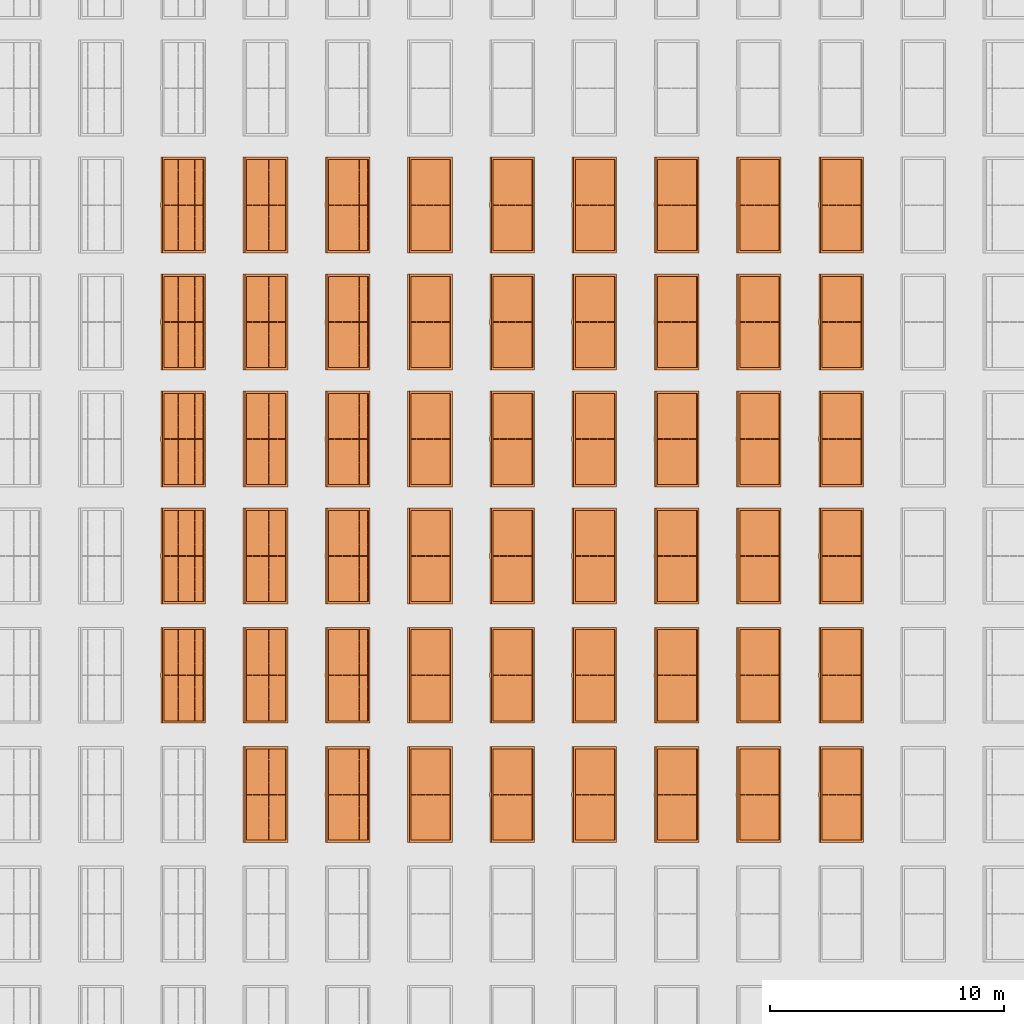
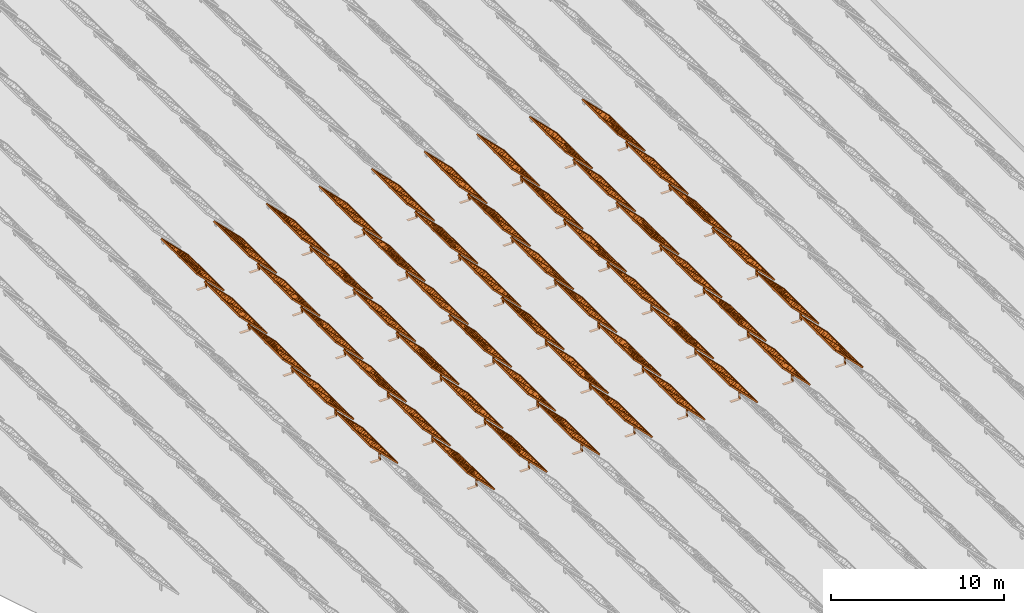
# One storey, part 17 of 39: 53 proxies.
"""IFC2X3 building model written with IfcOpenShell, lengths in millimetres."""

from ifc_helpers import new_model, entity, si_unit, converted_unit, derived_unit, direction, frame, frame_2d, origin, origin_2d_with_axis, place, context, subcontext, project, spatial, polyline, rectangle, outline, extrude, source, transform, mapped, material, material_list, element, save


model = new_model("IFC2X3")

# Units and contexts
model_context = context("Model", 3, precision=1e-06, world=origin(), true_north=direction((2.0, 6.12303176911189e-17, 1.0)))
context_of_model = context(None, 3, precision=1e-06, world=origin(), true_north=direction((2.0, 6.12303176911189e-17, 1.0)))
body_context = subcontext(model_context, "Body", "Model", "MODEL_VIEW")
ifc_project = project(units=[si_unit("LENGTHUNIT", "METRE", prefix="MILLI"), si_unit("AREAUNIT", "SQUARE_METRE", prefix="MILLI"), si_unit("VOLUMEUNIT", "CUBIC_METRE", prefix="MILLI"), converted_unit("PLANEANGLEUNIT", "DEGREE", entity("IfcRatioMeasure", 0.0174532925199433), si_unit("PLANEANGLEUNIT", "RADIAN"), dimensions=[0, 0, 0, 0, 0, 0, 0]), si_unit("MASSUNIT", "GRAM", prefix="KILO"), si_unit("TIMEUNIT", "SECOND"), si_unit("THERMODYNAMICTEMPERATUREUNIT", "KELVIN"), derived_unit("THERMALTRANSMITTANCEUNIT", [(si_unit("MASSUNIT", "GRAM", prefix="KILO"), 1), (si_unit("THERMODYNAMICTEMPERATUREUNIT", "KELVIN"), -1), (si_unit("TIMEUNIT", "SECOND"), -3)]), derived_unit("VOLUMETRICFLOWRATEUNIT", [(si_unit("LENGTHUNIT", "METRE"), 3), (si_unit("TIMEUNIT", "SECOND"), -1)])], contexts=[model_context, context_of_model])

# Site, building, storey
site_placement = place(None, origin())
site = spatial("IfcSite", under=ifc_project, at=site_placement, CompositionType="ELEMENT")
building_placement = place(site_placement, origin())
building = spatial("IfcBuilding", under=site, at=building_placement, CompositionType="ELEMENT")
storey_placement = place(building_placement, frame((0.0, 0.0, 4000.0)))
storey = spatial("IfcBuildingStorey", under=building, at=storey_placement, Name="Level 2", CompositionType="ELEMENT", Elevation=4000.0)

# Proxies
ifc_material_1 = material(Name="Stand-Steel")
ifc_material_2 = material(Name="Aluminium")
ifc_material_3 = material(Name="Glass")
ifc_material_list_1 = material_list([ifc_material_1, ifc_material_2, ifc_material_3])
shared_shape = source(origin(), body_context, "Body", "SweptSolid", [
    extrude(outline(polyline([(-629.526235435404, -220.0), (329.763117717702, -220.0), (329.763117717703, 410.0), (299.763117717703, 410.0), (299.763117717702, -190.0), (-629.526235435404, -190.0), (-629.526235435404, -220.0)])), frame((-190.00003127179, -100.0, 299.763117717707), z_axis=(0.0, 1.0, 0.0), x_axis=(0.0, 0.0, -1.0)), (0.0, 0.0, 1.0), 200.0),
    extrude(rectangle(XDim=20.0000000000001, YDim=200.0, at=frame_2d((0.0, -7.105427357601e-14), x_axis=(0.0, 1.0))), frame((-7.07109908365613, 0.0, 922.21828534124), z_axis=(-0.70710678118654, 0.0, 0.707106781186555), x_axis=(0.0, 1.0, 0.0)), (0.0, 0.0, 1.0), 2600.0),
    extrude(rectangle(XDim=24.9999999999997, YDim=24.9999999999999, at=frame_2d((2.87769807982841e-13, -9.50350909079134e-14), x_axis=(1.0, 0.0))), frame((-1449.56292018118, -1950.0, 2449.57494522722), z_axis=(0.0, 1.0, 0.0), x_axis=(-0.707106781186548, 0.0, -0.707106781186548)), (0.0, 0.0, 1.0), 3900.0),
    extrude(rectangle(XDim=24.9999999999999, YDim=25.0000000000001, at=origin_2d_with_axis()), frame((-1096.0095295879, -1950.0, 2096.02155463395), z_axis=(0.0, 1.0, 0.0), x_axis=(-0.707106781186542, 0.0, -0.707106781186553)), (0.0, 0.0, 1.0), 3900.0),
    extrude(rectangle(XDim=24.9999999999999, YDim=25.0000000000001, at=origin_2d_with_axis()), frame((-742.456138994631, -1950.0, 1742.46816404067), z_axis=(0.0, 1.0, 0.0), x_axis=(-0.707106781186542, 0.0, -0.707106781186553)), (0.0, 0.0, 1.0), 3900.0),
    extrude(rectangle(XDim=25.0, YDim=24.9999999999997, at=frame_2d((-7.19424519957101e-14, 1.19904086659517e-13), x_axis=(1.0, 0.0))), frame((-388.902748401358, -1950.0, 1388.9147734474), z_axis=(0.0, 1.0, 0.0), x_axis=(-0.707106781186545, 0.0, -0.70710678118655)), (0.0, 0.0, 1.0), 3900.0),
    extrude(rectangle(XDim=25.0000000000002, YDim=25.0, at=frame_2d((1.35891298214119e-13, 6.21724893790088e-15), x_axis=(0.0, 1.0))), frame((-35.3553703311048, 1500.0, 1035.35537033109), z_axis=(-0.707106781186544, 0.0, 0.707106781186551), x_axis=(0.0, 1.0, 0.0)), (0.0, 0.0, 1.0), 2440.0),
    extrude(rectangle(XDim=25.0000000000002, YDim=25.0, at=frame_2d((0.0, 1.77635683940025e-15), x_axis=(0.0, 1.0))), frame((-35.3553703311059, 1000.0, 1035.35537033109), z_axis=(-0.707106781186546, 0.0, 0.707106781186549), x_axis=(0.0, 1.0, 0.0)), (0.0, 0.0, 1.0), 2440.0),
    extrude(rectangle(XDim=25.0000000000002, YDim=25.0, at=frame_2d((0.0, 8.43769498715119e-14), x_axis=(0.0, 1.0))), frame((-26.5165355662756, 0.0, 1044.19420509593), z_axis=(-0.707106781186546, 0.0, 0.707106781186549), x_axis=(0.0, -1.0, 0.0)), (0.0, 0.0, 1.0), 2440.0),
    extrude(rectangle(XDim=25.0000000000002, YDim=25.0, at=frame_2d((0.0, 8.88178419700125e-16), x_axis=(0.0, 1.0))), frame((-35.3553703311065, 500.0, 1035.35537033109), z_axis=(-0.707106781186546, 0.0, 0.707106781186549), x_axis=(0.0, 1.0, 0.0)), (0.0, 0.0, 1.0), 2440.0),
    extrude(rectangle(XDim=25.0000000000002, YDim=25.0, at=frame_2d((0.0, 8.88178419700125e-16), x_axis=(0.0, 1.0))), frame((-35.3553703311086, -500.0, 1035.35537033109), z_axis=(-0.707106781186546, 0.0, 0.707106781186549), x_axis=(0.0, 1.0, 0.0)), (0.0, 0.0, 1.0), 2440.0),
    extrude(rectangle(XDim=25.0000000000002, YDim=25.0, at=frame_2d((0.0, 8.88178419700125e-16), x_axis=(0.0, 1.0))), frame((-35.3553703311095, -1000.0, 1035.35537033109), z_axis=(-0.707106781186546, 0.0, 0.707106781186549), x_axis=(0.0, 1.0, 0.0)), (0.0, 0.0, 1.0), 2440.0),
    extrude(rectangle(XDim=25.0000000000002, YDim=25.0, at=frame_2d((1.35891298214119e-13, 1.77635683940025e-15), x_axis=(0.0, 1.0))), frame((-35.3553703311107, -1500.0, 1035.35537033109), z_axis=(-0.707106781186546, 0.0, 0.707106781186549), x_axis=(0.0, 1.0, 0.0)), (0.0, 0.0, 1.0), 2440.0),
    extrude(rectangle(XDim=2400.0, YDim=11.9999999999994, at=frame_2d((-1.13686837721616e-13, 2.02948768901479e-13), x_axis=(1.0, 0.0))), frame((-883.883507754966, -1950.0, 1883.88350775495), z_axis=(0.0, 1.0, 0.0), x_axis=(0.707106781186546, 0.0, -0.707106781186549)), (0.0, 0.0, 1.0), 3900.0),
    extrude(outline(polyline([(-2050.0, -1300.0), (2050.0, -1300.0), (2050.0, 1300.0), (-2050.0, 1300.0), (-2050.0, -1300.0)]), holes=[polyline([(1950.0, -1200.0), (-1950.0, -1200.0), (-1950.0, 1200.0), (1950.0, 1200.0), (1950.0, -1200.0)])]), frame((-919.238846814293, 0.0, 1848.52816869563), z_axis=(0.707106781186554, 0.0, 0.707106781186541), x_axis=(0.0, 1.0, 0.0)), (0.0, 0.0, 1.0), 99.9999999999898),
])
proxy_1_placement = place(storey_placement, frame((-177460.32831183, 485144.680552409, 30.0)))
element("IfcBuildingElementProxy", 1, at=proxy_1_placement, inside=storey, material=ifc_material_list_1, Name="Solar Panel_4000X2500:Solar Panel_4000X2500", ObjectType="Solar Panel_4000X2500", CompositionType="ELEMENT", context=body_context, shape_type="MappedRepresentation", body=[
    mapped(shared_shape, transform((0.0, 0.0, 0.0), scale=1.0)),
])
ifc_material_list_2 = material_list([ifc_material_1, ifc_material_2, ifc_material_3])
proxy_2_placement = place(storey_placement, frame((-177460.32831183, 490144.680552409, 30.0)))
element("IfcBuildingElementProxy", 2, at=proxy_2_placement, inside=storey, material=ifc_material_list_2, Name="Solar Panel_4000X2500:Solar Panel_4000X2500", ObjectType="Solar Panel_4000X2500", CompositionType="ELEMENT", context=body_context, shape_type="MappedRepresentation", body=[
    mapped(shared_shape, transform((0.0, 0.0, 0.0), scale=1.0)),
])
ifc_material_list_3 = material_list([ifc_material_1, ifc_material_2, ifc_material_3])
proxy_3_placement = place(storey_placement, frame((-177460.32831183, 495144.680552409, 30.0)))
element("IfcBuildingElementProxy", 3, at=proxy_3_placement, inside=storey, material=ifc_material_list_3, Name="Solar Panel_4000X2500:Solar Panel_4000X2500", ObjectType="Solar Panel_4000X2500", CompositionType="ELEMENT", context=body_context, shape_type="MappedRepresentation", body=[
    mapped(shared_shape, transform((0.0, 0.0, 0.0), scale=1.0)),
])
ifc_material_list_4 = material_list([ifc_material_1, ifc_material_2, ifc_material_3])
proxy_4_placement = place(storey_placement, frame((-177460.32831183, 480144.680552409, 30.0)))
element("IfcBuildingElementProxy", 4, at=proxy_4_placement, inside=storey, material=ifc_material_list_4, Name="Solar Panel_4000X2500:Solar Panel_4000X2500", ObjectType="Solar Panel_4000X2500", CompositionType="ELEMENT", context=body_context, shape_type="MappedRepresentation", body=[
    mapped(shared_shape, transform((0.0, 0.0, 0.0), scale=1.0)),
])
ifc_material_list_5 = material_list([ifc_material_1, ifc_material_2, ifc_material_3])
proxy_5_placement = place(storey_placement, frame((-177460.32831183, 475044.680552409, 30.0)))
element("IfcBuildingElementProxy", 5, at=proxy_5_placement, inside=storey, material=ifc_material_list_5, Name="Solar Panel_4000X2500:Solar Panel_4000X2500", ObjectType="Solar Panel_4000X2500", CompositionType="ELEMENT", context=body_context, shape_type="MappedRepresentation", body=[
    mapped(shared_shape, transform((0.0, 0.0, 0.0), scale=1.0)),
])
ifc_material_list_6 = material_list([ifc_material_1, ifc_material_2, ifc_material_3])
proxy_6_placement = place(storey_placement, frame((-177460.32831183, 469944.680552409, 30.0)))
element("IfcBuildingElementProxy", 6, at=proxy_6_placement, inside=storey, material=ifc_material_list_6, Name="Solar Panel_4000X2500:Solar Panel_4000X2500", ObjectType="Solar Panel_4000X2500", CompositionType="ELEMENT", context=body_context, shape_type="MappedRepresentation", body=[
    mapped(shared_shape, transform((0.0, 0.0, 0.0), scale=1.0)),
])
ifc_material_list_7 = material_list([ifc_material_1, ifc_material_2, ifc_material_3])
proxy_7_placement = place(storey_placement, frame((-180975.32831183, 485144.680552409, 30.0)))
element("IfcBuildingElementProxy", 7, at=proxy_7_placement, inside=storey, material=ifc_material_list_7, Name="Solar Panel_4000X2500:Solar Panel_4000X2500", ObjectType="Solar Panel_4000X2500", CompositionType="ELEMENT", context=body_context, shape_type="MappedRepresentation", body=[
    mapped(shared_shape, transform((0.0, 0.0, 0.0), scale=1.0)),
])
ifc_material_list_8 = material_list([ifc_material_1, ifc_material_2, ifc_material_3])
proxy_8_placement = place(storey_placement, frame((-180975.32831183, 490144.680552409, 30.0)))
element("IfcBuildingElementProxy", 8, at=proxy_8_placement, inside=storey, material=ifc_material_list_8, Name="Solar Panel_4000X2500:Solar Panel_4000X2500", ObjectType="Solar Panel_4000X2500", CompositionType="ELEMENT", context=body_context, shape_type="MappedRepresentation", body=[
    mapped(shared_shape, transform((0.0, 0.0, 0.0), scale=1.0)),
])
ifc_material_list_9 = material_list([ifc_material_1, ifc_material_2, ifc_material_3])
proxy_9_placement = place(storey_placement, frame((-180975.32831183, 495144.680552409, 30.0)))
element("IfcBuildingElementProxy", 9, at=proxy_9_placement, inside=storey, material=ifc_material_list_9, Name="Solar Panel_4000X2500:Solar Panel_4000X2500", ObjectType="Solar Panel_4000X2500", CompositionType="ELEMENT", context=body_context, shape_type="MappedRepresentation", body=[
    mapped(shared_shape, transform((0.0, 0.0, 0.0), scale=1.0)),
])
ifc_material_list_10 = material_list([ifc_material_1, ifc_material_2, ifc_material_3])
proxy_10_placement = place(storey_placement, frame((-180975.32831183, 480144.680552409, 30.0)))
element("IfcBuildingElementProxy", 10, at=proxy_10_placement, inside=storey, material=ifc_material_list_10, Name="Solar Panel_4000X2500:Solar Panel_4000X2500", ObjectType="Solar Panel_4000X2500", CompositionType="ELEMENT", context=body_context, shape_type="MappedRepresentation", body=[
    mapped(shared_shape, transform((0.0, 0.0, 0.0), scale=1.0)),
])
ifc_material_list_11 = material_list([ifc_material_1, ifc_material_2, ifc_material_3])
proxy_11_placement = place(storey_placement, frame((-180975.32831183, 475044.680552409, 30.0)))
element("IfcBuildingElementProxy", 11, at=proxy_11_placement, inside=storey, material=ifc_material_list_11, Name="Solar Panel_4000X2500:Solar Panel_4000X2500", ObjectType="Solar Panel_4000X2500", CompositionType="ELEMENT", context=body_context, shape_type="MappedRepresentation", body=[
    mapped(shared_shape, transform((0.0, 0.0, 0.0), scale=1.0)),
])
ifc_material_list_12 = material_list([ifc_material_1, ifc_material_2, ifc_material_3])
proxy_12_placement = place(storey_placement, frame((-180975.32831183, 469944.680552409, 30.0)))
element("IfcBuildingElementProxy", 12, at=proxy_12_placement, inside=storey, material=ifc_material_list_12, Name="Solar Panel_4000X2500:Solar Panel_4000X2500", ObjectType="Solar Panel_4000X2500", CompositionType="ELEMENT", context=body_context, shape_type="MappedRepresentation", body=[
    mapped(shared_shape, transform((0.0, 0.0, 0.0), scale=1.0)),
])
ifc_material_list_13 = material_list([ifc_material_1, ifc_material_2, ifc_material_3])
proxy_13_placement = place(storey_placement, frame((-184490.32831183, 485144.680552409, 30.0)))
element("IfcBuildingElementProxy", 13, at=proxy_13_placement, inside=storey, material=ifc_material_list_13, Name="Solar Panel_4000X2500:Solar Panel_4000X2500", ObjectType="Solar Panel_4000X2500", CompositionType="ELEMENT", context=body_context, shape_type="MappedRepresentation", body=[
    mapped(shared_shape, transform((0.0, 0.0, 0.0), scale=1.0)),
])
ifc_material_list_14 = material_list([ifc_material_1, ifc_material_2, ifc_material_3])
proxy_14_placement = place(storey_placement, frame((-184490.32831183, 490144.680552409, 30.0)))
element("IfcBuildingElementProxy", 14, at=proxy_14_placement, inside=storey, material=ifc_material_list_14, Name="Solar Panel_4000X2500:Solar Panel_4000X2500", ObjectType="Solar Panel_4000X2500", CompositionType="ELEMENT", context=body_context, shape_type="MappedRepresentation", body=[
    mapped(shared_shape, transform((0.0, 0.0, 0.0), scale=1.0)),
])
ifc_material_list_15 = material_list([ifc_material_1, ifc_material_2, ifc_material_3])
proxy_15_placement = place(storey_placement, frame((-184490.32831183, 495144.680552409, 30.0)))
element("IfcBuildingElementProxy", 15, at=proxy_15_placement, inside=storey, material=ifc_material_list_15, Name="Solar Panel_4000X2500:Solar Panel_4000X2500", ObjectType="Solar Panel_4000X2500", CompositionType="ELEMENT", context=body_context, shape_type="MappedRepresentation", body=[
    mapped(shared_shape, transform((0.0, 0.0, 0.0), scale=1.0)),
])
ifc_material_list_16 = material_list([ifc_material_1, ifc_material_2, ifc_material_3])
proxy_16_placement = place(storey_placement, frame((-184490.32831183, 480144.680552409, 30.0)))
element("IfcBuildingElementProxy", 16, at=proxy_16_placement, inside=storey, material=ifc_material_list_16, Name="Solar Panel_4000X2500:Solar Panel_4000X2500", ObjectType="Solar Panel_4000X2500", CompositionType="ELEMENT", context=body_context, shape_type="MappedRepresentation", body=[
    mapped(shared_shape, transform((0.0, 0.0, 0.0), scale=1.0)),
])
ifc_material_list_17 = material_list([ifc_material_1, ifc_material_2, ifc_material_3])
proxy_17_placement = place(storey_placement, frame((-184490.32831183, 475044.680552409, 30.0)))
element("IfcBuildingElementProxy", 17, at=proxy_17_placement, inside=storey, material=ifc_material_list_17, Name="Solar Panel_4000X2500:Solar Panel_4000X2500", ObjectType="Solar Panel_4000X2500", CompositionType="ELEMENT", context=body_context, shape_type="MappedRepresentation", body=[
    mapped(shared_shape, transform((0.0, 0.0, 0.0), scale=1.0)),
])
ifc_material_list_18 = material_list([ifc_material_1, ifc_material_2, ifc_material_3])
proxy_18_placement = place(storey_placement, frame((-184490.32831183, 469944.680552409, 30.0)))
element("IfcBuildingElementProxy", 18, at=proxy_18_placement, inside=storey, material=ifc_material_list_18, Name="Solar Panel_4000X2500:Solar Panel_4000X2500", ObjectType="Solar Panel_4000X2500", CompositionType="ELEMENT", context=body_context, shape_type="MappedRepresentation", body=[
    mapped(shared_shape, transform((0.0, 0.0, 0.0), scale=1.0)),
])
ifc_material_list_19 = material_list([ifc_material_1, ifc_material_2, ifc_material_3])
proxy_19_placement = place(storey_placement, frame((-188005.32831183, 485144.680552409, 30.0)))
element("IfcBuildingElementProxy", 19, at=proxy_19_placement, inside=storey, material=ifc_material_list_19, Name="Solar Panel_4000X2500:Solar Panel_4000X2500", ObjectType="Solar Panel_4000X2500", CompositionType="ELEMENT", context=body_context, shape_type="MappedRepresentation", body=[
    mapped(shared_shape, transform((0.0, 0.0, 0.0), scale=1.0)),
])
ifc_material_list_20 = material_list([ifc_material_1, ifc_material_2, ifc_material_3])
proxy_20_placement = place(storey_placement, frame((-188005.32831183, 490144.680552409, 30.0)))
element("IfcBuildingElementProxy", 20, at=proxy_20_placement, inside=storey, material=ifc_material_list_20, Name="Solar Panel_4000X2500:Solar Panel_4000X2500", ObjectType="Solar Panel_4000X2500", CompositionType="ELEMENT", context=body_context, shape_type="MappedRepresentation", body=[
    mapped(shared_shape, transform((0.0, 0.0, 0.0), scale=1.0)),
])
ifc_material_list_21 = material_list([ifc_material_1, ifc_material_2, ifc_material_3])
proxy_21_placement = place(storey_placement, frame((-188005.32831183, 495144.680552409, 30.0)))
element("IfcBuildingElementProxy", 21, at=proxy_21_placement, inside=storey, material=ifc_material_list_21, Name="Solar Panel_4000X2500:Solar Panel_4000X2500", ObjectType="Solar Panel_4000X2500", CompositionType="ELEMENT", context=body_context, shape_type="MappedRepresentation", body=[
    mapped(shared_shape, transform((0.0, 0.0, 0.0), scale=1.0)),
])
ifc_material_list_22 = material_list([ifc_material_1, ifc_material_2, ifc_material_3])
proxy_22_placement = place(storey_placement, frame((-188005.32831183, 480144.680552409, 30.0)))
element("IfcBuildingElementProxy", 22, at=proxy_22_placement, inside=storey, material=ifc_material_list_22, Name="Solar Panel_4000X2500:Solar Panel_4000X2500", ObjectType="Solar Panel_4000X2500", CompositionType="ELEMENT", context=body_context, shape_type="MappedRepresentation", body=[
    mapped(shared_shape, transform((0.0, 0.0, 0.0), scale=1.0)),
])
ifc_material_list_23 = material_list([ifc_material_1, ifc_material_2, ifc_material_3])
proxy_23_placement = place(storey_placement, frame((-188005.32831183, 475044.680552409, 30.0)))
element("IfcBuildingElementProxy", 23, at=proxy_23_placement, inside=storey, material=ifc_material_list_23, Name="Solar Panel_4000X2500:Solar Panel_4000X2500", ObjectType="Solar Panel_4000X2500", CompositionType="ELEMENT", context=body_context, shape_type="MappedRepresentation", body=[
    mapped(shared_shape, transform((0.0, 0.0, 0.0), scale=1.0)),
])
ifc_material_list_24 = material_list([ifc_material_1, ifc_material_2, ifc_material_3])
proxy_24_placement = place(storey_placement, frame((-188005.32831183, 469944.680552409, 30.0)))
element("IfcBuildingElementProxy", 24, at=proxy_24_placement, inside=storey, material=ifc_material_list_24, Name="Solar Panel_4000X2500:Solar Panel_4000X2500", ObjectType="Solar Panel_4000X2500", CompositionType="ELEMENT", context=body_context, shape_type="MappedRepresentation", body=[
    mapped(shared_shape, transform((0.0, 0.0, 0.0), scale=1.0)),
])
ifc_material_list_25 = material_list([ifc_material_1, ifc_material_2, ifc_material_3])
proxy_25_placement = place(storey_placement, frame((-191520.32831183, 485144.680552409, 30.0)))
element("IfcBuildingElementProxy", 25, at=proxy_25_placement, inside=storey, material=ifc_material_list_25, Name="Solar Panel_4000X2500:Solar Panel_4000X2500", ObjectType="Solar Panel_4000X2500", CompositionType="ELEMENT", context=body_context, shape_type="MappedRepresentation", body=[
    mapped(shared_shape, transform((0.0, 0.0, 0.0), scale=1.0)),
])
ifc_material_list_26 = material_list([ifc_material_1, ifc_material_2, ifc_material_3])
proxy_26_placement = place(storey_placement, frame((-191520.32831183, 490144.680552409, 30.0)))
element("IfcBuildingElementProxy", 26, at=proxy_26_placement, inside=storey, material=ifc_material_list_26, Name="Solar Panel_4000X2500:Solar Panel_4000X2500", ObjectType="Solar Panel_4000X2500", CompositionType="ELEMENT", context=body_context, shape_type="MappedRepresentation", body=[
    mapped(shared_shape, transform((0.0, 0.0, 0.0), scale=1.0)),
])
ifc_material_list_27 = material_list([ifc_material_1, ifc_material_2, ifc_material_3])
proxy_27_placement = place(storey_placement, frame((-191520.32831183, 495144.680552409, 30.0)))
element("IfcBuildingElementProxy", 27, at=proxy_27_placement, inside=storey, material=ifc_material_list_27, Name="Solar Panel_4000X2500:Solar Panel_4000X2500", ObjectType="Solar Panel_4000X2500", CompositionType="ELEMENT", context=body_context, shape_type="MappedRepresentation", body=[
    mapped(shared_shape, transform((0.0, 0.0, 0.0), scale=1.0)),
])
ifc_material_list_28 = material_list([ifc_material_1, ifc_material_2, ifc_material_3])
proxy_28_placement = place(storey_placement, frame((-191520.32831183, 480144.680552409, 30.0)))
element("IfcBuildingElementProxy", 28, at=proxy_28_placement, inside=storey, material=ifc_material_list_28, Name="Solar Panel_4000X2500:Solar Panel_4000X2500", ObjectType="Solar Panel_4000X2500", CompositionType="ELEMENT", context=body_context, shape_type="MappedRepresentation", body=[
    mapped(shared_shape, transform((0.0, 0.0, 0.0), scale=1.0)),
])
ifc_material_list_29 = material_list([ifc_material_1, ifc_material_2, ifc_material_3])
proxy_29_placement = place(storey_placement, frame((-191520.32831183, 475044.680552409, 30.0)))
element("IfcBuildingElementProxy", 29, at=proxy_29_placement, inside=storey, material=ifc_material_list_29, Name="Solar Panel_4000X2500:Solar Panel_4000X2500", ObjectType="Solar Panel_4000X2500", CompositionType="ELEMENT", context=body_context, shape_type="MappedRepresentation", body=[
    mapped(shared_shape, transform((0.0, 0.0, 0.0), scale=1.0)),
])
ifc_material_list_30 = material_list([ifc_material_1, ifc_material_2, ifc_material_3])
proxy_30_placement = place(storey_placement, frame((-191520.32831183, 469944.680552409, 30.0)))
element("IfcBuildingElementProxy", 30, at=proxy_30_placement, inside=storey, material=ifc_material_list_30, Name="Solar Panel_4000X2500:Solar Panel_4000X2500", ObjectType="Solar Panel_4000X2500", CompositionType="ELEMENT", context=body_context, shape_type="MappedRepresentation", body=[
    mapped(shared_shape, transform((0.0, 0.0, 0.0), scale=1.0)),
])
ifc_material_list_31 = material_list([ifc_material_1, ifc_material_2, ifc_material_3])
proxy_31_placement = place(storey_placement, frame((-195035.32831183, 485144.680552409, 30.0)))
element("IfcBuildingElementProxy", 31, at=proxy_31_placement, inside=storey, material=ifc_material_list_31, Name="Solar Panel_4000X2500:Solar Panel_4000X2500", ObjectType="Solar Panel_4000X2500", CompositionType="ELEMENT", context=body_context, shape_type="MappedRepresentation", body=[
    mapped(shared_shape, transform((0.0, 0.0, 0.0), scale=1.0)),
])
ifc_material_list_32 = material_list([ifc_material_1, ifc_material_2, ifc_material_3])
proxy_32_placement = place(storey_placement, frame((-195035.32831183, 490144.680552409, 30.0)))
element("IfcBuildingElementProxy", 32, at=proxy_32_placement, inside=storey, material=ifc_material_list_32, Name="Solar Panel_4000X2500:Solar Panel_4000X2500", ObjectType="Solar Panel_4000X2500", CompositionType="ELEMENT", context=body_context, shape_type="MappedRepresentation", body=[
    mapped(shared_shape, transform((0.0, 0.0, 0.0), scale=1.0)),
])
ifc_material_list_33 = material_list([ifc_material_1, ifc_material_2, ifc_material_3])
proxy_33_placement = place(storey_placement, frame((-195035.32831183, 495144.680552409, 30.0)))
element("IfcBuildingElementProxy", 33, at=proxy_33_placement, inside=storey, material=ifc_material_list_33, Name="Solar Panel_4000X2500:Solar Panel_4000X2500", ObjectType="Solar Panel_4000X2500", CompositionType="ELEMENT", context=body_context, shape_type="MappedRepresentation", body=[
    mapped(shared_shape, transform((0.0, 0.0, 0.0), scale=1.0)),
])
ifc_material_list_34 = material_list([ifc_material_1, ifc_material_2, ifc_material_3])
proxy_34_placement = place(storey_placement, frame((-195035.32831183, 480144.680552409, 30.0)))
element("IfcBuildingElementProxy", 34, at=proxy_34_placement, inside=storey, material=ifc_material_list_34, Name="Solar Panel_4000X2500:Solar Panel_4000X2500", ObjectType="Solar Panel_4000X2500", CompositionType="ELEMENT", context=body_context, shape_type="MappedRepresentation", body=[
    mapped(shared_shape, transform((0.0, 0.0, 0.0), scale=1.0)),
])
ifc_material_list_35 = material_list([ifc_material_1, ifc_material_2, ifc_material_3])
proxy_35_placement = place(storey_placement, frame((-195035.32831183, 475044.680552409, 30.0)))
element("IfcBuildingElementProxy", 35, at=proxy_35_placement, inside=storey, material=ifc_material_list_35, Name="Solar Panel_4000X2500:Solar Panel_4000X2500", ObjectType="Solar Panel_4000X2500", CompositionType="ELEMENT", context=body_context, shape_type="MappedRepresentation", body=[
    mapped(shared_shape, transform((0.0, 0.0, 0.0), scale=1.0)),
])
ifc_material_list_36 = material_list([ifc_material_1, ifc_material_2, ifc_material_3])
proxy_36_placement = place(storey_placement, frame((-195035.32831183, 469944.680552409, 30.0)))
element("IfcBuildingElementProxy", 36, at=proxy_36_placement, inside=storey, material=ifc_material_list_36, Name="Solar Panel_4000X2500:Solar Panel_4000X2500", ObjectType="Solar Panel_4000X2500", CompositionType="ELEMENT", context=body_context, shape_type="MappedRepresentation", body=[
    mapped(shared_shape, transform((0.0, 0.0, 0.0), scale=1.0)),
])
ifc_material_list_37 = material_list([ifc_material_1, ifc_material_2, ifc_material_3])
proxy_37_placement = place(storey_placement, frame((-198550.32831183, 485144.680552409, 30.0)))
element("IfcBuildingElementProxy", 37, at=proxy_37_placement, inside=storey, material=ifc_material_list_37, Name="Solar Panel_4000X2500:Solar Panel_4000X2500", ObjectType="Solar Panel_4000X2500", CompositionType="ELEMENT", context=body_context, shape_type="MappedRepresentation", body=[
    mapped(shared_shape, transform((0.0, 0.0, 0.0), scale=1.0)),
])
ifc_material_list_38 = material_list([ifc_material_1, ifc_material_2, ifc_material_3])
proxy_38_placement = place(storey_placement, frame((-198550.32831183, 490144.680552409, 30.0)))
element("IfcBuildingElementProxy", 38, at=proxy_38_placement, inside=storey, material=ifc_material_list_38, Name="Solar Panel_4000X2500:Solar Panel_4000X2500", ObjectType="Solar Panel_4000X2500", CompositionType="ELEMENT", context=body_context, shape_type="MappedRepresentation", body=[
    mapped(shared_shape, transform((0.0, 0.0, 0.0), scale=1.0)),
])
ifc_material_list_39 = material_list([ifc_material_1, ifc_material_2, ifc_material_3])
proxy_39_placement = place(storey_placement, frame((-198550.32831183, 495144.680552409, 30.0)))
element("IfcBuildingElementProxy", 39, at=proxy_39_placement, inside=storey, material=ifc_material_list_39, Name="Solar Panel_4000X2500:Solar Panel_4000X2500", ObjectType="Solar Panel_4000X2500", CompositionType="ELEMENT", context=body_context, shape_type="MappedRepresentation", body=[
    mapped(shared_shape, transform((0.0, 0.0, 0.0), scale=1.0)),
])
ifc_material_list_40 = material_list([ifc_material_1, ifc_material_2, ifc_material_3])
proxy_40_placement = place(storey_placement, frame((-198550.32831183, 480144.680552409, 30.0)))
element("IfcBuildingElementProxy", 40, at=proxy_40_placement, inside=storey, material=ifc_material_list_40, Name="Solar Panel_4000X2500:Solar Panel_4000X2500", ObjectType="Solar Panel_4000X2500", CompositionType="ELEMENT", context=body_context, shape_type="MappedRepresentation", body=[
    mapped(shared_shape, transform((0.0, 0.0, 0.0), scale=1.0)),
])
ifc_material_list_41 = material_list([ifc_material_1, ifc_material_2, ifc_material_3])
proxy_41_placement = place(storey_placement, frame((-198550.32831183, 475044.680552409, 30.0)))
element("IfcBuildingElementProxy", 41, at=proxy_41_placement, inside=storey, material=ifc_material_list_41, Name="Solar Panel_4000X2500:Solar Panel_4000X2500", ObjectType="Solar Panel_4000X2500", CompositionType="ELEMENT", context=body_context, shape_type="MappedRepresentation", body=[
    mapped(shared_shape, transform((0.0, 0.0, 0.0), scale=1.0)),
])
ifc_material_list_42 = material_list([ifc_material_1, ifc_material_2, ifc_material_3])
proxy_42_placement = place(storey_placement, frame((-198550.32831183, 469944.680552409, 30.0)))
element("IfcBuildingElementProxy", 42, at=proxy_42_placement, inside=storey, material=ifc_material_list_42, Name="Solar Panel_4000X2500:Solar Panel_4000X2500", ObjectType="Solar Panel_4000X2500", CompositionType="ELEMENT", context=body_context, shape_type="MappedRepresentation", body=[
    mapped(shared_shape, transform((0.0, 0.0, 0.0), scale=1.0)),
])
ifc_material_list_43 = material_list([ifc_material_1, ifc_material_2, ifc_material_3])
proxy_43_placement = place(storey_placement, frame((-202065.32831183, 485144.680552409, 30.0)))
element("IfcBuildingElementProxy", 43, at=proxy_43_placement, inside=storey, material=ifc_material_list_43, Name="Solar Panel_4000X2500:Solar Panel_4000X2500", ObjectType="Solar Panel_4000X2500", CompositionType="ELEMENT", context=body_context, shape_type="MappedRepresentation", body=[
    mapped(shared_shape, transform((0.0, 0.0, 0.0), scale=1.0)),
])
ifc_material_list_44 = material_list([ifc_material_1, ifc_material_2, ifc_material_3])
proxy_44_placement = place(storey_placement, frame((-202065.32831183, 490144.680552409, 30.0)))
element("IfcBuildingElementProxy", 44, at=proxy_44_placement, inside=storey, material=ifc_material_list_44, Name="Solar Panel_4000X2500:Solar Panel_4000X2500", ObjectType="Solar Panel_4000X2500", CompositionType="ELEMENT", context=body_context, shape_type="MappedRepresentation", body=[
    mapped(shared_shape, transform((0.0, 0.0, 0.0), scale=1.0)),
])
ifc_material_list_45 = material_list([ifc_material_1, ifc_material_2, ifc_material_3])
proxy_45_placement = place(storey_placement, frame((-202065.32831183, 495144.680552409, 30.0)))
element("IfcBuildingElementProxy", 45, at=proxy_45_placement, inside=storey, material=ifc_material_list_45, Name="Solar Panel_4000X2500:Solar Panel_4000X2500", ObjectType="Solar Panel_4000X2500", CompositionType="ELEMENT", context=body_context, shape_type="MappedRepresentation", body=[
    mapped(shared_shape, transform((0.0, 0.0, 0.0), scale=1.0)),
])
ifc_material_list_46 = material_list([ifc_material_1, ifc_material_2, ifc_material_3])
proxy_46_placement = place(storey_placement, frame((-202065.32831183, 480144.680552409, 30.0)))
element("IfcBuildingElementProxy", 46, at=proxy_46_placement, inside=storey, material=ifc_material_list_46, Name="Solar Panel_4000X2500:Solar Panel_4000X2500", ObjectType="Solar Panel_4000X2500", CompositionType="ELEMENT", context=body_context, shape_type="MappedRepresentation", body=[
    mapped(shared_shape, transform((0.0, 0.0, 0.0), scale=1.0)),
])
ifc_material_list_47 = material_list([ifc_material_1, ifc_material_2, ifc_material_3])
proxy_47_placement = place(storey_placement, frame((-202065.32831183, 475044.680552409, 30.0)))
element("IfcBuildingElementProxy", 47, at=proxy_47_placement, inside=storey, material=ifc_material_list_47, Name="Solar Panel_4000X2500:Solar Panel_4000X2500", ObjectType="Solar Panel_4000X2500", CompositionType="ELEMENT", context=body_context, shape_type="MappedRepresentation", body=[
    mapped(shared_shape, transform((0.0, 0.0, 0.0), scale=1.0)),
])
ifc_material_list_48 = material_list([ifc_material_1, ifc_material_2, ifc_material_3])
proxy_48_placement = place(storey_placement, frame((-202065.32831183, 469944.680552409, 30.0)))
element("IfcBuildingElementProxy", 48, at=proxy_48_placement, inside=storey, material=ifc_material_list_48, Name="Solar Panel_4000X2500:Solar Panel_4000X2500", ObjectType="Solar Panel_4000X2500", CompositionType="ELEMENT", context=body_context, shape_type="MappedRepresentation", body=[
    mapped(shared_shape, transform((0.0, 0.0, 0.0), scale=1.0)),
])
ifc_material_list_49 = material_list([ifc_material_1, ifc_material_2, ifc_material_3])
proxy_49_placement = place(storey_placement, frame((-205580.32831183, 485144.680552409, 30.0)))
element("IfcBuildingElementProxy", 49, at=proxy_49_placement, inside=storey, material=ifc_material_list_49, Name="Solar Panel_4000X2500:Solar Panel_4000X2500", ObjectType="Solar Panel_4000X2500", CompositionType="ELEMENT", context=body_context, shape_type="MappedRepresentation", body=[
    mapped(shared_shape, transform((0.0, 0.0, 0.0), scale=1.0)),
])
ifc_material_list_50 = material_list([ifc_material_1, ifc_material_2, ifc_material_3])
proxy_50_placement = place(storey_placement, frame((-205580.32831183, 490144.680552409, 30.0)))
element("IfcBuildingElementProxy", 50, at=proxy_50_placement, inside=storey, material=ifc_material_list_50, Name="Solar Panel_4000X2500:Solar Panel_4000X2500", ObjectType="Solar Panel_4000X2500", CompositionType="ELEMENT", context=body_context, shape_type="MappedRepresentation", body=[
    mapped(shared_shape, transform((0.0, 0.0, 0.0), scale=1.0)),
])
ifc_material_list_51 = material_list([ifc_material_1, ifc_material_2, ifc_material_3])
proxy_51_placement = place(storey_placement, frame((-205580.32831183, 495144.680552409, 30.0)))
element("IfcBuildingElementProxy", 51, at=proxy_51_placement, inside=storey, material=ifc_material_list_51, Name="Solar Panel_4000X2500:Solar Panel_4000X2500", ObjectType="Solar Panel_4000X2500", CompositionType="ELEMENT", context=body_context, shape_type="MappedRepresentation", body=[
    mapped(shared_shape, transform((0.0, 0.0, 0.0), scale=1.0)),
])
ifc_material_list_52 = material_list([ifc_material_1, ifc_material_2, ifc_material_3])
proxy_52_placement = place(storey_placement, frame((-205580.32831183, 480144.680552409, 30.0)))
element("IfcBuildingElementProxy", 52, at=proxy_52_placement, inside=storey, material=ifc_material_list_52, Name="Solar Panel_4000X2500:Solar Panel_4000X2500", ObjectType="Solar Panel_4000X2500", CompositionType="ELEMENT", context=body_context, shape_type="MappedRepresentation", body=[
    mapped(shared_shape, transform((0.0, 0.0, 0.0), scale=1.0)),
])
ifc_material_list_53 = material_list([ifc_material_1, ifc_material_2, ifc_material_3])
proxy_53_placement = place(storey_placement, frame((-205580.32831183, 475044.680552409, 30.0)))
element("IfcBuildingElementProxy", 53, at=proxy_53_placement, inside=storey, material=ifc_material_list_53, Name="Solar Panel_4000X2500:Solar Panel_4000X2500", ObjectType="Solar Panel_4000X2500", CompositionType="ELEMENT", context=body_context, shape_type="MappedRepresentation", body=[
    mapped(shared_shape, transform((0.0, 0.0, 0.0), scale=1.0)),
])

save(model, "model.ifc")
